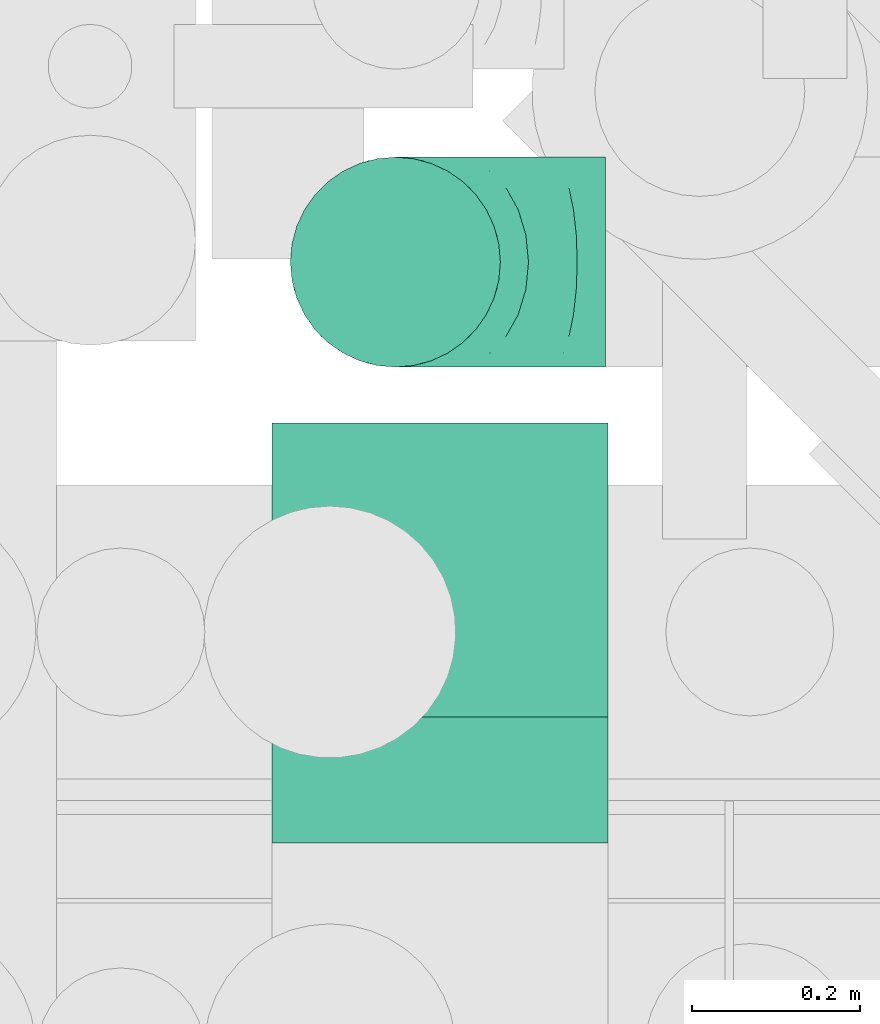
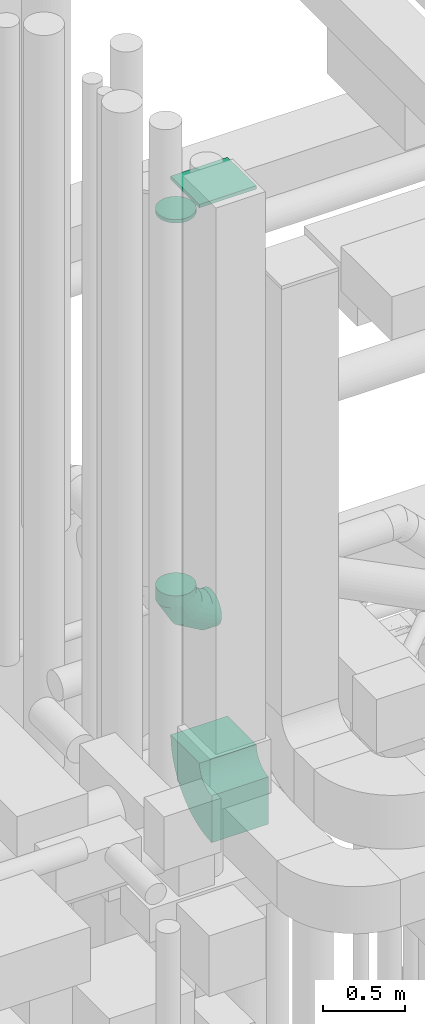
# One storey, part 224 of 337: 4 flow fittings.
"""IFC2X3 building model written with IfcOpenShell, lengths in millimetres."""

import ifcopenshell
import ifcopenshell.guid

model = None  # the IFC model being written
_history = None  # IfcOwnerHistory: only IFC2X3 demands one
_inside = {}  # id of a spatial element -> (the spatial element, [elements in it])
_under = {}  # id of a project, library or spatial element -> (it, [spatial elements below it])
_declared = {}  # id of a project -> (the project, [libraries it declares])
_typed = {}  # id of a type object -> (the type object, [elements of that type])
_made_of = {}  # id of a material, layer set ... -> (it, [elements and type objects made of it])


def new_model(schema):
    """Start an empty IFC model of exactly this schema.

    Asked for "IFC4X3", IfcOpenShell would pick the latest addendum, in which some entities
    have other attributes; the version numbers below select the first issue.
    IFC2X3 requires an IfcOwnerHistory on every rooted entity: one is made here for all.
    """
    global model, _history
    if schema == "IFC4X3":
        model = ifcopenshell.file(schema_version=(4, 3, 0, 0))
    else:
        model = ifcopenshell.file(schema=schema)
    _inside.clear()
    _under.clear()
    _declared.clear()
    _typed.clear()
    _made_of.clear()
    _history = None
    if model.schema == "IFC2X3":
        org = make("IfcOrganization", Name="unknown")
        user = make(
            "IfcPersonAndOrganization",
            ThePerson=make("IfcPerson", FamilyName="unknown"),
            TheOrganization=org,
        )
        app = make(
            "IfcApplication",
            ApplicationDeveloper=org,
            Version="unknown",
            ApplicationFullName="unknown",
            ApplicationIdentifier="unknown",
        )
        _history = make(
            "IfcOwnerHistory",
            OwningUser=user,
            OwningApplication=app,
            ChangeAction="ADDED",
            CreationDate=0,
        )
    return model


def make(cls, **values):
    """One entity of the class cls with the attributes given. An attribute that is None is left unset."""
    return model.create_entity(
        cls, **{name: value for name, value in values.items() if value is not None}
    )


def entity(cls, *values):
    """Any entity or typed value of the class cls, its attributes in the order of the schema. None: left unset."""
    e = model.create_entity(cls)
    for i, value in enumerate(values):
        if value is not None:
            e[i] = value
    return e


def rooted(cls, **values):
    """An entity with a GlobalId (a new one), such as an element, a storey or a relation."""
    return make(cls, GlobalId=ifcopenshell.guid.new(), OwnerHistory=_history, **values)


def si_unit(unit_type, name, prefix=None):
    """IfcSIUnit, for example si_unit("LENGTHUNIT", "METRE", prefix="MILLI")."""
    return make("IfcSIUnit", UnitType=unit_type, Prefix=prefix, Name=name)


def converted_unit(unit_type, name, factor, base, dimensions=None, offset=None):
    """IfcConversionBasedUnit, such as the inch: factor (a typed value) times the base unit."""
    return make(
        "IfcConversionBasedUnit"
        if offset is None
        else "IfcConversionBasedUnitWithOffset",
        ConversionOffset=offset,
        Dimensions=None
        if dimensions is None
        else entity("IfcDimensionalExponents", *dimensions),
        UnitType=unit_type,
        Name=name,
        ConversionFactor=make(
            "IfcMeasureWithUnit", ValueComponent=factor, UnitComponent=base
        ),
    )


def derived_unit(unit_type, elements):
    """IfcDerivedUnit: a product of units, each with its exponent."""
    return make(
        "IfcDerivedUnit",
        Elements=[
            make("IfcDerivedUnitElement", Unit=unit, Exponent=power)
            for unit, power in elements
        ],
        UnitType=unit_type,
    )


def assignment(units):
    """IfcUnitAssignment: the units of a project."""
    return None if units is None else make("IfcUnitAssignment", Units=units)


def point(xyz):
    """IfcCartesianPoint."""
    return None if xyz is None else make("IfcCartesianPoint", Coordinates=xyz)


def direction(xyz):
    """IfcDirection."""
    return None if xyz is None else make("IfcDirection", DirectionRatios=xyz)


def frame(location, z_axis=None, x_axis=None):
    """IfcAxis2Placement3D, a coordinate frame: its origin and axes. An axis left out is left unset."""
    return make(
        "IfcAxis2Placement3D",
        Location=point(location),
        Axis=direction(z_axis),
        RefDirection=direction(x_axis),
    )


def frame_2d(location, x_axis=None):
    """IfcAxis2Placement2D, a coordinate frame in the plane: its origin and x axis."""
    return make(
        "IfcAxis2Placement2D", Location=point(location), RefDirection=direction(x_axis)
    )


def origin():
    """The frame at (0, 0, 0) with its axes left unset."""
    return frame((0.0, 0.0, 0.0))


def origin_2d_with_axis():
    """The frame at (0, 0) in the plane with the x axis (1, 0) written out."""
    return frame_2d((0.0, 0.0), x_axis=(1.0, 0.0))


def place(relative_to, where):
    """IfcLocalPlacement: puts the frame where relative to a parent placement (None: the world)."""
    return make(
        "IfcLocalPlacement", PlacementRelTo=relative_to, RelativePlacement=where
    )


def context(
    kind, dimensions, precision=None, world=None, true_north=None, identifier=None
):
    """IfcGeometricRepresentationContext, for example the 3D "Model" context."""
    return make(
        "IfcGeometricRepresentationContext",
        ContextIdentifier=identifier,
        ContextType=kind,
        CoordinateSpaceDimension=dimensions,
        Precision=precision,
        WorldCoordinateSystem=world,
        TrueNorth=true_north,
    )


def subcontext(parent, identifier, kind, view, scale=None):
    """IfcGeometricRepresentationSubContext, for example "Body" below "Model"."""
    return make(
        "IfcGeometricRepresentationSubContext",
        ContextIdentifier=identifier,
        ContextType=kind,
        ParentContext=parent,
        TargetScale=scale,
        TargetView=view,
    )


def project(units=None, contexts=None):
    """IfcProject with its units and contexts."""
    return rooted(
        "IfcProject",
        Name="project",
        RepresentationContexts=contexts,
        UnitsInContext=assignment(units),
    )


def spatial(cls, under=None, at=None, **own):
    """A site, building, storey or space (cls), placed at a placement, below another one or the project."""
    s = rooted(cls, ObjectPlacement=at, **own)
    if under is not None:
        _under.setdefault(under.id(), (under, []))[1].append(s)
    return s


def polyline(points):
    """IfcPolyline through the points."""
    return make("IfcPolyline", Points=[point(p) for p in points])


def circle_curve(where, radius):
    """IfcCircle in the frame where."""
    return make("IfcCircle", Position=where, Radius=radius)


def parameter(value):
    """IfcParameterValue: where a trimmed curve begins or ends, as a parameter of its basis curve."""
    return model.create_entity("IfcParameterValue", value)


def trimmed(basis, trim1, trim2, sense, master):
    """IfcTrimmedCurve: the piece of a basis curve between two trims."""
    return make(
        "IfcTrimmedCurve",
        BasisCurve=basis,
        Trim1=trim1,
        Trim2=trim2,
        SenseAgreement=sense,
        MasterRepresentation=master,
    )


def segment(curve, same_sense, transition):
    """IfcCompositeCurveSegment."""
    return make(
        "IfcCompositeCurveSegment",
        Transition=transition,
        SameSense=same_sense,
        ParentCurve=curve,
    )


def composite_curve(segments, self_intersect=None):
    """IfcCompositeCurve: segments joined end to end."""
    return make("IfcCompositeCurve", Segments=segments, SelfIntersect=self_intersect)


def profile(cls, at=None, kind="AREA", **sizes):
    """A parametric profile (cls). Its sizes go by their IFC names, for example OverallWidth=200.0."""
    return make(cls, ProfileType=kind, Position=at, **sizes)


def rectangle(**sizes):
    """IfcRectangleProfileDef."""
    return profile("IfcRectangleProfileDef", **sizes)


def circle(**sizes):
    """IfcCircleProfileDef."""
    return profile("IfcCircleProfileDef", **sizes)


def outline(outer, holes=None, kind="AREA"):
    """IfcArbitraryClosedProfileDef: a profile drawn as a closed curve; with holes, ...WithVoids."""
    if holes is None:
        return make("IfcArbitraryClosedProfileDef", ProfileType=kind, OuterCurve=outer)
    return make(
        "IfcArbitraryProfileDefWithVoids",
        ProfileType=kind,
        OuterCurve=outer,
        InnerCurves=holes,
    )


def extrude(swept, where, along, depth):
    """IfcExtrudedAreaSolid: the profile swept, set in the frame where, extruded along a direction by depth."""
    return make(
        "IfcExtrudedAreaSolid",
        SweptArea=swept,
        Position=where,
        ExtrudedDirection=direction(along),
        Depth=depth,
    )


def faces_of(points, faces, orient=None, outer=None):
    """IfcFace entities. A face is a list of loops; a loop is a list of indices into points, from 0.

    orient and outer hold one flag for each loop. By default every Orientation is true, the
    first loop of a face is its IfcFaceOuterBound and the others are IfcFaceBound.
    """
    made = []
    for i, loops in enumerate(faces):
        bounds = []
        for j, loop in enumerate(loops):
            is_outer = j == 0 if outer is None else outer[i][j]
            bounds.append(
                make(
                    "IfcFaceOuterBound" if is_outer else "IfcFaceBound",
                    Bound=make("IfcPolyLoop", Polygon=[points[k] for k in loop]),
                    Orientation=True if orient is None else orient[i][j],
                )
            )
        made.append(make("IfcFace", Bounds=bounds))
    return made


def faceted_brep(points, faces, orient=None, outer=None, voids=None):
    """IfcFacetedBrep: a solid bounded by flat faces; with voids (closed shells), ...WithVoids."""
    shared = [point(p) for p in points]
    hull = make("IfcClosedShell", CfsFaces=faces_of(shared, faces, orient, outer))
    if voids is None:
        return make("IfcFacetedBrep", Outer=hull)
    return make(
        "IfcFacetedBrepWithVoids",
        Outer=hull,
        Voids=[
            make(cls, CfsFaces=faces_of(shared, fs, o, b)) for cls, fs, o, b in voids
        ],
    )


def shape(context_of_items, identifier, shape_type, items):
    """IfcShapeRepresentation: the items that make up one representation, for example the "Body"."""
    return make(
        "IfcShapeRepresentation",
        ContextOfItems=context_of_items,
        RepresentationIdentifier=identifier,
        RepresentationType=shape_type,
        Items=items,
    )


def source(mapping_origin, context_of_items, identifier, shape_type, items):
    """IfcRepresentationMap: a shape defined once, which mapped items show again and again."""
    return make(
        "IfcRepresentationMap",
        MappingOrigin=mapping_origin,
        MappedRepresentation=shape(context_of_items, identifier, shape_type, items),
    )


def transform(
    local_origin,
    x_axis=None,
    y_axis=None,
    z_axis=None,
    scale=None,
    scale2=None,
    scale3=None,
    uniform=True,
):
    """IfcCartesianTransformationOperator3D, or its non-uniform kind. x_axis, y_axis, z_axis: its Axis1, 2, 3."""
    if uniform:
        return make(
            "IfcCartesianTransformationOperator3D",
            Axis1=direction(x_axis),
            Axis2=direction(y_axis),
            LocalOrigin=point(local_origin),
            Scale=scale,
            Axis3=direction(z_axis),
        )
    return make(
        "IfcCartesianTransformationOperator3DnonUniform",
        Axis1=direction(x_axis),
        Axis2=direction(y_axis),
        LocalOrigin=point(local_origin),
        Scale=scale,
        Axis3=direction(z_axis),
        Scale2=scale2,
        Scale3=scale3,
    )


def mapped(mapping_source, mapping_target):
    """IfcMappedItem: shows the shape of a source again, moved by a transform."""
    return make(
        "IfcMappedItem", MappingSource=mapping_source, MappingTarget=mapping_target
    )


def material(Name=None, Category=None):
    """IfcMaterial."""
    return make("IfcMaterial", Name=Name, Category=Category)


def made_of(thing, what):
    """Note that an element or type object is made of a material, layer set ...; save() writes the relation."""
    if what is not None:
        _made_of.setdefault(what.id(), (what, []))[1].append(thing)
    return thing


def type_object(cls, material=None, **own):
    """A type object (cls), such as IfcWallType, which elements share."""
    return made_of(rooted(cls, **own), material)


def type_shapes(of_type, sources):
    """Give a type object the sources (RepresentationMaps) that its elements show as mapped items."""
    of_type.RepresentationMaps = sources


def element(
    cls,
    number,
    at=None,
    inside=None,
    cuts=None,
    type_object=None,
    material=None,
    context=None,
    identifier="Body",
    shape_type=None,
    held_by="IfcProductDefinitionShape",
    body=None,
    shapes=None,
    **own,
):
    """One element of the class cls, such as IfcWall. Its Tag is "e" and its number.

    at: its placement. inside: the storey or other place that contains it. cuts: it is an
    opening in that element (IfcRelVoidsElement). A single representation is given by context,
    identifier, shape_type and body (its items); several are given by shapes. held_by: the class
    of the entity that holds the representations. save() writes the other relations.
    """
    e = rooted(cls, Tag="e%d" % number, ObjectPlacement=at, **own)
    if body is not None:
        shapes = [shape(context, identifier, shape_type, body)]
    if shapes is not None:
        e.Representation = make(held_by, Representations=shapes)
    if inside is not None:
        _inside.setdefault(inside.id(), (inside, []))[1].append(e)
    if cuts is not None:
        rooted(
            "IfcRelVoidsElement", RelatingBuildingElement=cuts, RelatedOpeningElement=e
        )
    if type_object is not None:
        _typed.setdefault(type_object.id(), (type_object, []))[1].append(e)
    return made_of(e, material)


def aggregate(whole, parts):
    """IfcRelAggregates: a whole, such as a stair, and the parts it consists of."""
    return rooted("IfcRelAggregates", RelatingObject=whole, RelatedObjects=parts)


def save(model, path):
    """Write the relations noted so far, then the file.

    IfcRelAggregates (storeys below a building ...), IfcRelContainedInSpatialStructure (elements
    in a storey), IfcRelDefinesByType, IfcRelAssociatesMaterial and IfcRelDeclares: one each for
    every whole, place, type object, material and project.
    """
    for whole, parts in _under.values():
        aggregate(whole, parts)
    for where, things in _inside.values():
        rooted(
            "IfcRelContainedInSpatialStructure",
            RelatedElements=things,
            RelatingStructure=where,
        )
    for kind, things in _typed.values():
        rooted("IfcRelDefinesByType", RelatedObjects=things, RelatingType=kind)
    for what, things in _made_of.values():
        rooted("IfcRelAssociatesMaterial", RelatedObjects=things, RelatingMaterial=what)
    for by, libraries in _declared.values():
        rooted("IfcRelDeclares", RelatingContext=by, RelatedDefinitions=libraries)
    model.write(path)


model = new_model("IFC2X3")

# Units and contexts
model_context = context("Model", 3, precision=0.01, world=origin(), true_north=direction((6.12303176911189e-17, 1.0)))
body_context = subcontext(model_context, "Body", "Model", "MODEL_VIEW")
ifc_project = project(units=[si_unit("LENGTHUNIT", "METRE", prefix="MILLI"), si_unit("AREAUNIT", "SQUARE_METRE"), si_unit("VOLUMEUNIT", "CUBIC_METRE"), converted_unit("PLANEANGLEUNIT", "DEGREE", entity("IfcRatioMeasure", 0.0174532925199433), si_unit("PLANEANGLEUNIT", "RADIAN"), dimensions=[0, 0, 0, 0, 0, 0, 0]), si_unit("MASSUNIT", "GRAM", prefix="KILO"), derived_unit("MASSDENSITYUNIT", [(si_unit("MASSUNIT", "GRAM", prefix="KILO"), 1), (si_unit("LENGTHUNIT", "METRE"), -3)]), derived_unit("MOMENTOFINERTIAUNIT", [(si_unit("LENGTHUNIT", "METRE"), 4)]), si_unit("TIMEUNIT", "SECOND"), si_unit("FREQUENCYUNIT", "HERTZ"), si_unit("THERMODYNAMICTEMPERATUREUNIT", "DEGREE_CELSIUS"), derived_unit("THERMALTRANSMITTANCEUNIT", [(si_unit("MASSUNIT", "GRAM", prefix="KILO"), 1), (si_unit("THERMODYNAMICTEMPERATUREUNIT", "KELVIN"), -1), (si_unit("TIMEUNIT", "SECOND"), -3)]), derived_unit("VOLUMETRICFLOWRATEUNIT", [(si_unit("LENGTHUNIT", "METRE"), 3), (si_unit("TIMEUNIT", "SECOND"), -1)]), derived_unit("MASSFLOWRATEUNIT", [(si_unit("MASSUNIT", "GRAM", prefix="KILO"), 1), (si_unit("TIMEUNIT", "SECOND"), -1)]), derived_unit("ROTATIONALFREQUENCYUNIT", [(si_unit("TIMEUNIT", "SECOND"), -1)]), si_unit("ELECTRICCURRENTUNIT", "AMPERE"), si_unit("ELECTRICVOLTAGEUNIT", "VOLT"), si_unit("POWERUNIT", "WATT"), si_unit("FORCEUNIT", "NEWTON", prefix="KILO"), si_unit("ILLUMINANCEUNIT", "LUX"), si_unit("LUMINOUSFLUXUNIT", "LUMEN"), si_unit("LUMINOUSINTENSITYUNIT", "CANDELA"), derived_unit("USERDEFINED", [(si_unit("MASSUNIT", "GRAM", prefix="KILO"), -1), (si_unit("LENGTHUNIT", "METRE"), -2), (si_unit("TIMEUNIT", "SECOND"), 3), (si_unit("LUMINOUSFLUXUNIT", "LUMEN"), 1)]), derived_unit("LINEARVELOCITYUNIT", [(si_unit("LENGTHUNIT", "METRE"), 1), (si_unit("TIMEUNIT", "SECOND"), -1)]), si_unit("PRESSUREUNIT", "PASCAL"), derived_unit("USERDEFINED", [(si_unit("LENGTHUNIT", "METRE"), -2), (si_unit("MASSUNIT", "GRAM", prefix="KILO"), 1), (si_unit("TIMEUNIT", "SECOND"), -2)]), derived_unit("LINEARFORCEUNIT", [(si_unit("MASSUNIT", "GRAM", prefix="KILO"), 1), (si_unit("LENGTHUNIT", "METRE"), 1), (si_unit("TIMEUNIT", "SECOND"), -2), (si_unit("LENGTHUNIT", "METRE"), -1)]), derived_unit("PLANARFORCEUNIT", [(si_unit("MASSUNIT", "GRAM", prefix="KILO"), 1), (si_unit("LENGTHUNIT", "METRE"), 1), (si_unit("TIMEUNIT", "SECOND"), -2), (si_unit("LENGTHUNIT", "METRE"), -2)])], contexts=[model_context])

# Site, building, storey
site_placement = place(None, origin())
site = spatial("IfcSite", under=ifc_project, at=site_placement, CompositionType="ELEMENT")
building_placement = place(site_placement, origin())
building = spatial("IfcBuilding", under=site, at=building_placement, CompositionType="ELEMENT")
storey_placement = place(building_placement, origin())
storey = spatial("IfcBuildingStorey", under=building, at=storey_placement, CompositionType="ELEMENT", Elevation=0.0)

# Flow fittings
ifc_material = material()
duct_fitting_type_1 = type_object("IfcDuctFittingType", PredefinedType="NOTDEFINED", material=ifc_material)
shared_shape_1 = source(origin(), body_context, "Body", "SweptSolid", [
    extrude(circle(Radius=124.999999999999, at=origin_2d_with_axis()), frame((0.0, 0.0, 0.0), z_axis=(1.0, 0.0, 0.0), x_axis=(0.0, 1.0, 0.0)), (0.0, 0.0, 1.0), 25.0000000000018),
])
type_shapes(duct_fitting_type_1, [shared_shape_1])
flow_fitting_1_placement = place(storey_placement, frame((55958.0, 10674.5, 34820.0), z_axis=(1.0, 0.0, 0.0), x_axis=(0.0, 0.0, 1.0)))
element("IfcFlowFitting", 1, at=flow_fitting_1_placement, inside=storey, type_object=duct_fitting_type_1, material=ifc_material, context=body_context, shape_type="MappedRepresentation", body=[
    mapped(shared_shape_1, transform((0.0, 0.0, 0.0), scale=1.0)),
])
duct_fitting_type_2 = type_object("IfcDuctFittingType", PredefinedType="NOTDEFINED", material=ifc_material)
shared_shape_2 = source(origin(), body_context, "Body", "SweptSolid", [
    extrude(rectangle(XDim=24.9999999999999, YDim=400.0, at=origin_2d_with_axis()), frame((12.5, 0.0, -175.0)), (0.0, 0.0, 1.0), 350.0),
])
type_shapes(duct_fitting_type_2, [shared_shape_2])
flow_fitting_2_placement = place(storey_placement, frame((56011.0, 10308.0, 35225.17), z_axis=(0.0, -1.0, 0.0), x_axis=(0.0, 0.0, 1.0)))
element("IfcFlowFitting", 2, at=flow_fitting_2_placement, inside=storey, type_object=duct_fitting_type_2, material=ifc_material, context=body_context, shape_type="MappedRepresentation", body=[
    mapped(shared_shape_2, transform((0.0, 0.0, 0.0), scale=1.0)),
])
duct_fitting_type_3 = type_object("IfcDuctFittingType", PredefinedType="NOTDEFINED", material=ifc_material)
shared_shape_3 = source(origin(), body_context, "Body", "Brep", [
    faceted_brep([(-250.0, 0.0, -125.0), (-250.0, -32.35, -120.74), (-250.0, -62.5, -108.25), (-250.0, -88.39, -88.39), (-250.0, -108.25, -62.5), (-250.0, -120.74, -32.35), (-250.0, -125.0, 0.0), (-250.0, -120.74, 32.35), (-250.0, -108.25, 62.5), (-250.0, -88.39, 88.39), (-250.0, -62.5, 108.25), (-250.0, -32.35, 120.74), (-250.0, 0.0, 125.0), (-250.0, 32.35, 120.74), (-250.0, 62.5, 108.25), (-250.0, 88.39, 88.39), (-250.0, 108.25, 62.5), (-250.0, 120.74, 32.35), (-250.0, 125.0, 0.0), (-250.0, 120.74, -32.35), (-250.0, 108.25, -62.5), (-250.0, 88.39, -88.39), (-250.0, 62.5, -108.25), (-250.0, 32.35, -120.74), (-191.68, 32.35, 120.74), (-199.76, 62.5, 108.25), (-183.01, 0.0, 125.0), (-206.7, 88.39, 88.39), (-215.37, 120.74, 32.35), (-216.51, 125.0, 0.0), (-212.02, 108.25, 62.5), (-212.02, 108.25, -62.5), (-206.7, 88.39, -88.39), (-215.37, 120.74, -32.35), (-191.68, 32.35, -120.74), (-183.01, 0.0, -125.0), (-199.76, 62.5, -108.25), (-174.34, -32.35, -120.74), (-166.27, -62.5, -108.25), (-159.33, -88.39, -88.39), (-154.01, -108.25, -62.5), (-150.66, -120.74, -32.35), (-149.52, -125.0, 0.0), (-150.66, -120.74, 32.35), (-154.01, -108.25, 62.5), (-159.33, -88.39, 88.39), (-166.27, -62.5, 108.25), (-174.34, -32.35, 120.74), (-90.67, 90.67, 120.74), (-112.74, 112.74, 108.25), (-66.99, 66.99, 125.0), (-131.69, 131.69, 88.39), (-146.23, 146.23, 62.5), (-155.38, 155.38, 32.35), (-158.49, 158.49, 0.0), (-155.38, 155.38, -32.35), (-146.23, 146.23, -62.5), (-131.69, 131.69, -88.39), (-90.67, 90.67, -120.74), (-66.99, 66.99, -125.0), (-112.74, 112.74, -108.25), (-43.3, 43.3, -120.74), (-21.23, 21.23, -108.25), (-2.28, 2.28, -88.39), (12.26, -12.26, -62.5), (21.4, -21.4, -32.35), (24.52, -24.52, 0.0), (21.4, -21.4, 32.35), (12.26, -12.26, 62.5), (-2.28, 2.28, 88.39), (-21.23, 21.23, 108.25), (-43.3, 43.3, 120.74), (-32.35, 191.68, 120.74), (-62.5, 199.76, 108.25), (0.0, 183.01, 125.0), (-88.39, 206.7, 88.39), (-108.25, 212.02, 62.5), (-120.74, 215.37, 32.35), (-125.0, 216.51, 0.0), (-120.74, 215.37, -32.35), (-108.25, 212.02, -62.5), (-88.39, 206.7, -88.39), (-32.35, 191.68, -120.74), (0.0, 183.01, -125.0), (-62.5, 199.76, -108.25), (32.35, 174.34, -120.74), (62.5, 166.27, -108.25), (88.39, 159.33, -88.39), (108.25, 154.01, -62.5), (120.74, 150.66, -32.35), (125.0, 149.52, 0.0), (120.74, 150.66, 32.35), (108.25, 154.01, 62.5), (88.39, 159.33, 88.39), (62.5, 166.27, 108.25), (32.35, 174.34, 120.74), (-32.35, 250.0, -120.74), (-62.5, 250.0, -108.25), (-88.39, 250.0, -88.39), (-108.25, 250.0, -62.5), (-120.74, 250.0, -32.35), (-125.0, 250.0, 0.0), (-120.74, 250.0, 32.35), (-108.25, 250.0, 62.5), (-88.39, 250.0, 88.39), (-62.5, 250.0, 108.25), (-32.35, 250.0, 120.74), (0.0, 250.0, 125.0), (32.35, 250.0, 120.74), (62.5, 250.0, 108.25), (88.39, 250.0, 88.39), (108.25, 250.0, 62.5), (120.74, 250.0, 32.35), (125.0, 250.0, 0.0), (120.74, 250.0, -32.35), (108.25, 250.0, -62.5), (88.39, 250.0, -88.39), (62.5, 250.0, -108.25), (32.35, 250.0, -120.74), (0.0, 250.0, -125.0)], [[[0, 1, 2, 3, 4, 5, 6, 7, 8, 9, 10, 11, 12, 13, 14, 15, 16, 17, 18, 19, 20, 21, 22, 23]], [[24, 25, 14, 13]], [[26, 24, 13, 12]], [[14, 25, 27, 15]], [[28, 29, 18, 17]], [[30, 28, 17, 16]], [[15, 27, 30, 16]], [[20, 31, 32, 21]], [[33, 31, 20, 19]], [[18, 29, 33, 19]], [[34, 35, 0, 23]], [[36, 34, 23, 22]], [[21, 32, 36, 22]], [[1, 0, 35, 37]], [[2, 1, 37, 38]], [[38, 39, 3, 2]], [[5, 4, 40, 41]], [[6, 5, 41, 42]], [[39, 40, 4, 3]], [[6, 42, 43, 7]], [[7, 43, 44, 8]], [[8, 44, 45, 9]], [[9, 45, 46, 10]], [[10, 46, 47, 11]], [[26, 12, 11, 47]], [[48, 49, 25, 24]], [[50, 48, 24, 26]], [[27, 25, 49, 51]], [[52, 53, 28, 30]], [[51, 52, 30, 27]], [[29, 28, 53, 54]], [[55, 56, 31, 33]], [[54, 55, 33, 29]], [[32, 31, 56, 57]], [[58, 59, 35, 34]], [[60, 58, 34, 36]], [[57, 60, 36, 32]], [[37, 35, 59, 61]], [[38, 37, 61, 62]], [[39, 38, 62, 63]], [[41, 40, 64, 65]], [[42, 41, 65, 66]], [[63, 64, 40, 39]], [[43, 42, 66, 67]], [[44, 43, 67, 68]], [[68, 69, 45, 44]], [[46, 45, 69, 70]], [[47, 46, 70, 71]], [[26, 47, 71, 50]], [[72, 73, 49, 48]], [[74, 72, 48, 50]], [[51, 49, 73, 75]], [[76, 77, 53, 52]], [[75, 76, 52, 51]], [[54, 53, 77, 78]], [[79, 80, 56, 55]], [[78, 79, 55, 54]], [[57, 56, 80, 81]], [[82, 83, 59, 58]], [[84, 82, 58, 60]], [[81, 84, 60, 57]], [[61, 59, 83, 85]], [[62, 61, 85, 86]], [[63, 62, 86, 87]], [[65, 64, 88, 89]], [[66, 65, 89, 90]], [[87, 88, 64, 63]], [[67, 66, 90, 91]], [[68, 67, 91, 92]], [[92, 93, 69, 68]], [[70, 69, 93, 94]], [[71, 70, 94, 95]], [[50, 71, 95, 74]], [[96, 97, 98, 99, 100, 101, 102, 103, 104, 105, 106, 107, 108, 109, 110, 111, 112, 113, 114, 115, 116, 117, 118, 119]], [[72, 74, 107, 106]], [[73, 72, 106, 105]], [[75, 73, 105, 104]], [[77, 76, 103, 102]], [[78, 77, 102, 101]], [[75, 104, 103, 76]], [[78, 101, 100, 79]], [[79, 100, 99, 80]], [[80, 99, 98, 81]], [[84, 97, 96, 82]], [[82, 96, 119, 83]], [[84, 81, 98, 97]], [[83, 119, 118, 85]], [[85, 118, 117, 86]], [[116, 87, 86, 117]], [[88, 115, 114, 89]], [[89, 114, 113, 90]], [[115, 88, 87, 116]], [[91, 90, 113, 112]], [[92, 91, 112, 111]], [[111, 110, 93, 92]], [[95, 94, 109, 108]], [[74, 95, 108, 107]], [[110, 109, 94, 93]]]),
])
type_shapes(duct_fitting_type_3, [shared_shape_3])
flow_fitting_3_placement = place(storey_placement, frame((55958.0, 10674.5, 31800.0), z_axis=(0.0, -1.0, 0.0), x_axis=(0.0, 0.0, -1.0)))
element("IfcFlowFitting", 3, at=flow_fitting_3_placement, inside=storey, type_object=duct_fitting_type_3, material=ifc_material, context=body_context, shape_type="MappedRepresentation", body=[
    mapped(shared_shape_3, transform((0.0, 0.0, 0.0), scale=1.0)),
])
duct_fitting_type_4 = type_object("IfcDuctFittingType", PredefinedType="NOTDEFINED", material=ifc_material)
shared_shape_4 = source(origin(), body_context, "Body", "SweptSolid", [
    extrude(outline(composite_curve([segment(polyline([(-337.5, -162.5), (12.5, -162.5)]), True, "CONTINUOUS"), segment(trimmed(circle_curve(frame_2d((162.5, -162.5), x_axis=(0.0, 1.0)), 150.0), [parameter(0.0)], [parameter(90.0000000000001)], True, "PARAMETER"), False, "CONTINUOUS"), segment(polyline([(162.5, -12.5), (162.5, 337.5)]), True, "CONTINUOUS"), segment(trimmed(circle_curve(frame_2d((162.5, -162.5), x_axis=(0.0, 1.0)), 500.0), [parameter(0.0)], [parameter(90.0000000000001)], True, "PARAMETER"), True, "CONTINUOUS")], self_intersect=False)), frame((-162.5, 162.5, -200.0), z_axis=(0.0, 0.0, 1.0), x_axis=(-1.0, 0.0, 0.0)), (0.0, 0.0, 1.0), 400.0),
])
type_shapes(duct_fitting_type_4, [shared_shape_4])
flow_fitting_4_placement = place(storey_placement, frame((56011.0, 10308.0, 30775.0), z_axis=(1.0, 0.0, 0.0), x_axis=(0.0, 1.0, 0.0)))
element("IfcFlowFitting", 4, at=flow_fitting_4_placement, inside=storey, type_object=duct_fitting_type_4, material=ifc_material, context=body_context, shape_type="MappedRepresentation", body=[
    mapped(shared_shape_4, transform((0.0, 0.0, 0.0), scale=1.0)),
])

save(model, "model.ifc")
